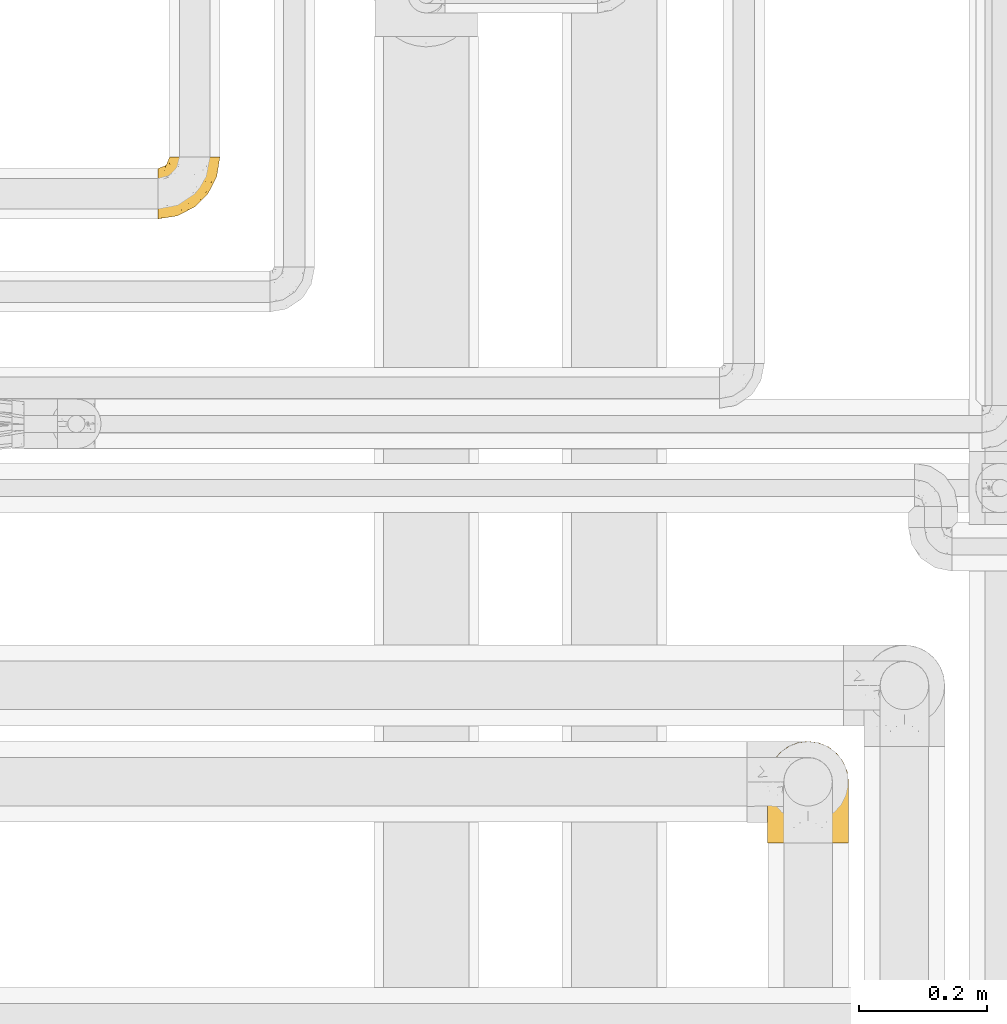
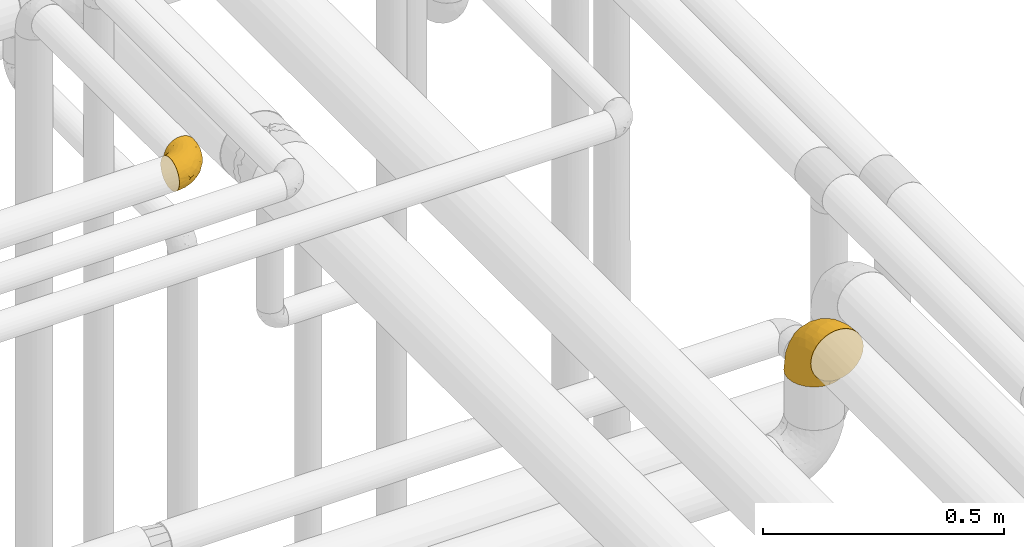
# One storey, part 494 of 827: 2 coverings.
"""IFC2X3 building model written with IfcOpenShell, lengths in millimetres."""

from ifc_helpers import new_model, entity, si_unit, converted_unit, derived_unit, direction, frame, origin, place, context, subcontext, project, spatial, faceted_brep, element, save


model = new_model("IFC2X3")

# Units and contexts
model_context = context("Model", 3, precision=0.01, world=origin(), true_north=direction((6.12303176911189e-17, 1.0)))
body_context = subcontext(model_context, "Body", "Model", "MODEL_VIEW")
ifc_project = project(units=[si_unit("LENGTHUNIT", "METRE", prefix="MILLI"), si_unit("AREAUNIT", "SQUARE_METRE"), si_unit("VOLUMEUNIT", "CUBIC_METRE"), converted_unit("PLANEANGLEUNIT", "DEGREE", entity("IfcRatioMeasure", 0.0174532925199433), si_unit("PLANEANGLEUNIT", "RADIAN"), dimensions=[0, 0, 0, 0, 0, 0, 0]), si_unit("MASSUNIT", "GRAM", prefix="KILO"), derived_unit("MASSDENSITYUNIT", [(si_unit("MASSUNIT", "GRAM", prefix="KILO"), 1), (si_unit("LENGTHUNIT", "METRE"), -3)]), derived_unit("MOMENTOFINERTIAUNIT", [(si_unit("LENGTHUNIT", "METRE"), 4)]), si_unit("TIMEUNIT", "SECOND"), si_unit("FREQUENCYUNIT", "HERTZ"), si_unit("THERMODYNAMICTEMPERATUREUNIT", "DEGREE_CELSIUS"), derived_unit("THERMALTRANSMITTANCEUNIT", [(si_unit("MASSUNIT", "GRAM", prefix="KILO"), 1), (si_unit("THERMODYNAMICTEMPERATUREUNIT", "KELVIN"), -1), (si_unit("TIMEUNIT", "SECOND"), -3)]), derived_unit("VOLUMETRICFLOWRATEUNIT", [(si_unit("LENGTHUNIT", "METRE"), 3), (si_unit("TIMEUNIT", "SECOND"), -1)]), derived_unit("MASSFLOWRATEUNIT", [(si_unit("MASSUNIT", "GRAM", prefix="KILO"), 1), (si_unit("TIMEUNIT", "SECOND"), -1)]), derived_unit("ROTATIONALFREQUENCYUNIT", [(si_unit("TIMEUNIT", "SECOND"), -1)]), si_unit("ELECTRICCURRENTUNIT", "AMPERE"), si_unit("ELECTRICVOLTAGEUNIT", "VOLT"), si_unit("POWERUNIT", "WATT"), si_unit("FORCEUNIT", "NEWTON", prefix="KILO"), si_unit("ILLUMINANCEUNIT", "LUX"), si_unit("LUMINOUSFLUXUNIT", "LUMEN"), si_unit("LUMINOUSINTENSITYUNIT", "CANDELA"), derived_unit("USERDEFINED", [(si_unit("MASSUNIT", "GRAM", prefix="KILO"), -1), (si_unit("LENGTHUNIT", "METRE"), -2), (si_unit("TIMEUNIT", "SECOND"), 3), (si_unit("LUMINOUSFLUXUNIT", "LUMEN"), 1)]), derived_unit("LINEARVELOCITYUNIT", [(si_unit("LENGTHUNIT", "METRE"), 1), (si_unit("TIMEUNIT", "SECOND"), -1)]), si_unit("PRESSUREUNIT", "PASCAL"), derived_unit("USERDEFINED", [(si_unit("LENGTHUNIT", "METRE"), -2), (si_unit("MASSUNIT", "GRAM", prefix="KILO"), 1), (si_unit("TIMEUNIT", "SECOND"), -2)]), derived_unit("LINEARFORCEUNIT", [(si_unit("MASSUNIT", "GRAM", prefix="KILO"), 1), (si_unit("LENGTHUNIT", "METRE"), 1), (si_unit("TIMEUNIT", "SECOND"), -2), (si_unit("LENGTHUNIT", "METRE"), -1)]), derived_unit("PLANARFORCEUNIT", [(si_unit("MASSUNIT", "GRAM", prefix="KILO"), 1), (si_unit("LENGTHUNIT", "METRE"), 1), (si_unit("TIMEUNIT", "SECOND"), -2), (si_unit("LENGTHUNIT", "METRE"), -2)])], contexts=[model_context])

# Site, building, storey
site_placement = place(None, origin())
site = spatial("IfcSite", under=ifc_project, at=site_placement, CompositionType="ELEMENT")
building_placement = place(site_placement, origin())
building = spatial("IfcBuilding", under=site, at=building_placement, CompositionType="ELEMENT")
storey_placement = place(building_placement, frame((0.0, 0.0, 28200.0)))
storey = spatial("IfcBuildingStorey", under=building, at=storey_placement, Name="08", CompositionType="ELEMENT", Elevation=28200.0)

# Coverings
covering_1_placement = place(storey_placement, frame((59739.54, 16797.19, 3159.25)))
element("IfcCovering", 1, at=covering_1_placement, inside=storey, Name=":ADSK_", ObjectType=":ADSK_", PredefinedType="INSULATION", context=body_context, shape_type="Brep", body=[
    faceted_brep([(58.6, 97.75, 79.9), (67.31, 97.75, 78.91), (75.59, 97.75, 76.02), (83.01, 97.75, 71.35), (89.21, 97.75, 65.15), (93.87, 97.75, 57.73), (96.76, 97.75, 49.45), (97.75, 97.75, 40.75), (96.76, 97.75, 32.03), (93.87, 97.75, 23.75), (89.2, 97.75, 16.33), (83.0, 97.75, 10.13), (75.58, 97.75, 5.47), (67.3, 97.75, 2.58), (58.6, 97.75, 1.6), (55.4, 97.75, 1.96), (49.88, 97.75, 2.58), (45.74, 97.75, 4.03), (41.6, 97.75, 5.48), (34.18, 97.75, 10.14), (27.98, 97.75, 16.34), (23.32, 97.75, 23.76), (20.43, 97.75, 32.04), (19.45, 97.75, 40.75), (20.43, 97.75, 49.46), (23.33, 97.75, 57.74), (27.99, 97.75, 65.16), (34.19, 97.75, 71.36), (41.61, 97.75, 76.02), (49.89, 97.75, 78.91), (55.4, 97.75, 79.54), (1.6, 68.43, 13.06), (1.6, 60.32, 6.84), (1.6, 50.88, 2.93), (1.6, 47.16, 2.44), (1.6, 43.95, 2.02), (1.6, 40.75, 1.6), (1.6, 30.61, 2.93), (1.6, 21.17, 6.84), (1.6, 13.06, 13.06), (1.6, 6.84, 21.17), (1.6, 2.93, 30.61), (1.6, 1.6, 40.75), (1.6, 2.93, 50.88), (1.6, 6.84, 60.32), (1.6, 13.06, 68.43), (1.6, 21.17, 74.65), (1.6, 30.61, 78.56), (1.6, 40.75, 79.9), (1.6, 47.16, 79.05), (1.6, 50.88, 78.56), (1.6, 60.32, 74.65), (1.6, 68.43, 68.43), (1.6, 74.65, 60.32), (1.6, 78.56, 50.88), (1.6, 79.9, 40.75), (1.6, 78.56, 30.61), (1.6, 74.65, 21.17), (68.75, 30.59, 40.75), (79.38, 41.23, 40.75), (67.95, 31.39, 53.99), (58.11, 19.96, 40.75), (31.31, 6.3, 40.75), (25.48, 5.21, 47.49), (20.85, 4.64, 40.75), (48.28, 15.42, 51.52), (38.29, 15.6, 61.86), (24.38, 6.88, 54.43), (18.7, 10.45, 63.37), (63.4, 80.79, 79.25), (43.9, 39.87, 77.04), (21.15, 25.91, 75.79), (41.26, 28.57, 72.61), (20.94, 35.0, 78.93), (24.69, 18.15, 70.12), (84.73, 74.57, 66.7), (79.29, 80.38, 72.7), (75.09, 59.65, 70.21), (55.53, 59.36, 78.8), (54.26, 75.93, 79.9), (51.17, 71.31, 79.9), (48.08, 66.69, 79.9), (44.99, 62.06, 79.9), (41.9, 57.44, 79.9), (59.1, 46.63, 74.44), (93.12, 74.83, 52.47), (38.11, 45.67, 79.33), (37.28, 54.35, 79.9), (32.65, 51.26, 79.9), (28.03, 48.17, 79.9), (23.41, 45.08, 79.9), (86.26, 54.03, 48.94), (84.36, 58.15, 58.78), (90.84, 80.8, 60.43), (94.7, 78.49, 40.75), (62.67, 31.82, 62.02), (76.37, 43.52, 57.53), (57.88, 94.17, 79.9), (57.17, 90.6, 79.9), (55.75, 83.46, 79.9), (74.1, 47.16, 64.12), (68.09, 64.11, 75.76), (72.38, 81.54, 76.65), (61.34, 38.43, 68.92), (48.69, 25.45, 66.73), (44.71, 13.13, 40.75), (93.04, 68.03, 40.75), (15.88, 43.59, 79.9), (12.31, 42.88, 79.9), (8.74, 42.17, 79.9), (86.21, 54.63, 40.75), (7.55, 73.05, 63.86), (12.14, 69.6, 69.15), (11.84, 51.66, 78.65), (9.55, 63.89, 72.98), (10.89, 57.82, 76.47), (17.57, 59.13, 76.82), (19.53, 52.25, 79.05), (25.5, 54.86, 79.09), (7.5, 79.38, 51.28), (12.73, 82.07, 51.03), (14.22, 85.12, 40.75), (8.19, 82.63, 40.75), (18.5, 89.2, 49.93), (20.38, 86.06, 58.53), (27.96, 81.78, 69.86), (22.53, 81.63, 65.19), (25.05, 76.19, 70.75), (51.05, 90.86, 79.25), (49.37, 85.89, 79.11), (6.49, 76.5, 57.89), (21.79, 92.32, 55.93), (37.29, 70.11, 78.06), (28.49, 69.83, 75.39), (33.82, 65.67, 78.16), (18.63, 76.0, 66.62), (21.37, 68.84, 73.14), (33.2, 91.37, 71.07), (42.33, 76.37, 78.32), (34.77, 83.17, 73.93), (42.81, 85.98, 77.25), (48.27, 79.95, 79.26), (17.49, 81.01, 60.3), (16.71, 91.15, 40.75), (26.81, 88.52, 65.72), (31.65, 75.86, 74.5), (12.9, 77.41, 60.62), (16.9, 64.86, 73.96), (23.37, 60.69, 77.3), (28.95, 62.7, 77.83), (6.49, 76.5, 23.6), (10.35, 73.85, 17.57), (57.88, 94.17, 1.6), (57.17, 90.6, 1.6), (55.75, 83.46, 1.6), (18.5, 89.2, 31.57), (20.37, 86.06, 22.97), (21.79, 92.32, 25.57), (26.8, 88.52, 15.78), (15.88, 43.59, 1.6), (8.74, 42.17, 1.6), (5.17, 41.46, 1.6), (12.14, 69.6, 12.34), (16.74, 64.84, 7.57), (10.0, 64.5, 8.85), (18.6, 52.81, 2.63), (17.57, 59.13, 4.67), (25.3, 54.5, 2.36), (23.41, 45.08, 1.6), (11.84, 51.66, 2.84), (48.27, 79.95, 2.24), (51.17, 71.31, 1.6), (42.31, 76.38, 3.18), (25.03, 76.18, 10.74), (18.73, 76.44, 15.18), (22.25, 81.43, 16.42), (7.5, 79.38, 30.21), (20.15, 70.71, 9.98), (12.73, 82.07, 30.46), (33.19, 91.37, 10.43), (27.5, 81.89, 12.05), (42.79, 85.98, 4.24), (34.75, 83.17, 7.56), (37.29, 70.11, 3.43), (49.36, 85.9, 2.38), (54.26, 75.93, 1.6), (28.95, 62.7, 3.66), (22.98, 61.23, 4.45), (31.63, 75.83, 6.98), (28.42, 69.82, 6.12), (10.01, 58.44, 5.38), (17.3, 81.13, 21.58), (48.08, 66.69, 1.6), (12.9, 77.41, 20.87), (33.78, 65.71, 3.35), (37.28, 54.35, 1.6), (41.9, 57.44, 1.6), (44.99, 62.06, 1.6), (28.03, 48.17, 1.6), (32.65, 51.26, 1.6), (38.11, 45.67, 2.16), (24.7, 18.15, 11.37), (21.15, 25.91, 5.7), (41.27, 28.58, 8.88), (61.33, 38.43, 12.57), (59.09, 46.64, 7.04), (75.08, 59.66, 11.27), (74.09, 47.16, 17.36), (55.53, 59.36, 2.69), (20.94, 35.0, 2.56), (25.48, 5.21, 34.0), (24.38, 6.88, 27.06), (43.89, 39.88, 4.45), (68.08, 64.12, 5.73), (18.7, 10.45, 18.12), (38.29, 15.6, 19.63), (67.95, 31.39, 27.49), (62.66, 31.82, 19.46), (63.4, 80.8, 2.24), (93.12, 74.83, 29.01), (84.73, 74.57, 14.78), (86.25, 54.02, 32.55), (79.28, 80.38, 8.78), (48.28, 15.42, 29.98), (76.37, 43.52, 23.95), (84.35, 58.15, 22.7), (90.83, 80.8, 21.05), (48.7, 25.47, 14.75), (72.37, 81.54, 4.84)], [[[0, 1, 2, 3, 4, 5, 6, 7, 8, 9, 10, 11, 12, 13, 14, 15, 16, 17, 18, 19, 20, 21, 22, 23, 24, 25, 26, 27, 28, 29, 30]], [[31, 32, 33, 34, 35, 36, 37, 38, 39, 40, 41, 42, 43, 44, 45, 46, 47, 48, 49, 50, 51, 52, 53, 54, 55, 56, 57]], [[58, 59, 60, 61]], [[62, 63, 64]], [[65, 66, 67]], [[67, 66, 68]], [[69, 1, 0]], [[70, 71, 72]], [[44, 43, 67]], [[47, 71, 73]], [[45, 74, 46]], [[68, 45, 44]], [[75, 76, 77]], [[76, 3, 2]], [[78, 79, 80, 81, 82, 83]], [[48, 47, 73]], [[70, 72, 84]], [[5, 85, 6]], [[86, 83, 87, 88, 89, 90]], [[91, 85, 92]], [[76, 75, 3]], [[71, 46, 74]], [[85, 5, 93]], [[45, 68, 74]], [[5, 4, 93]], [[85, 94, 6]], [[86, 78, 83]], [[60, 95, 65]], [[96, 95, 60]], [[75, 4, 3]], [[69, 0, 97, 98, 99, 79]], [[75, 77, 100]], [[43, 64, 63]], [[101, 102, 69]], [[101, 76, 102]], [[46, 71, 47]], [[95, 103, 104]], [[92, 85, 93]], [[63, 105, 65]], [[92, 75, 100]], [[91, 106, 85]], [[84, 78, 70]], [[67, 68, 44]], [[65, 67, 63]], [[65, 61, 60]], [[4, 75, 93]], [[92, 93, 75]], [[102, 76, 2]], [[77, 76, 101]], [[84, 77, 101]], [[77, 103, 100]], [[72, 71, 74]], [[70, 86, 73]], [[104, 74, 66]], [[84, 72, 103]], [[70, 73, 71]], [[73, 90, 107, 108, 109, 48]], [[79, 78, 69]], [[101, 69, 78]], [[91, 92, 96]], [[91, 59, 110, 106]], [[2, 1, 102]], [[69, 102, 1]], [[94, 85, 106]], [[94, 7, 6]], [[74, 68, 66]], [[43, 42, 64]], [[43, 63, 67]], [[73, 86, 90]], [[78, 86, 70]], [[95, 100, 103]], [[96, 92, 100]], [[104, 103, 72]], [[65, 95, 66]], [[74, 104, 72]], [[66, 95, 104]], [[95, 96, 100]], [[91, 96, 60]], [[77, 84, 103]], [[78, 84, 101]], [[60, 59, 91]], [[105, 63, 62]], [[105, 61, 65]], [[111, 52, 112]], [[107, 90, 113]], [[114, 115, 116]], [[50, 107, 113]], [[117, 118, 116]], [[54, 119, 55]], [[97, 0, 30, 29, 98]], [[113, 115, 51]], [[120, 121, 122]], [[123, 120, 124]], [[125, 126, 127]], [[128, 28, 129]], [[130, 54, 53]], [[25, 24, 131]], [[132, 133, 134]], [[135, 112, 136]], [[137, 27, 26]], [[121, 120, 123]], [[138, 139, 132]], [[129, 140, 141]], [[135, 126, 142]], [[27, 140, 28]], [[27, 137, 140]], [[49, 48, 109, 108, 107, 50]], [[23, 143, 121, 123]], [[25, 131, 144]], [[26, 25, 144]], [[128, 98, 29]], [[125, 127, 145]], [[146, 130, 111]], [[137, 144, 139]], [[139, 138, 140]], [[116, 147, 114]], [[123, 124, 131]], [[116, 118, 148]], [[138, 132, 81]], [[129, 79, 99]], [[54, 130, 119]], [[141, 79, 129]], [[122, 55, 119]], [[120, 146, 142]], [[117, 113, 90]], [[50, 113, 51]], [[127, 133, 145]], [[147, 136, 112]], [[136, 133, 127]], [[24, 23, 123]], [[118, 117, 89]], [[149, 87, 134]], [[144, 131, 124]], [[24, 123, 131]], [[128, 129, 99]], [[28, 140, 129]], [[144, 137, 26]], [[140, 137, 139]], [[134, 82, 132]], [[138, 80, 141]], [[89, 88, 87, 118]], [[115, 117, 116]], [[140, 138, 141]], [[148, 118, 149]], [[136, 148, 149]], [[147, 116, 148]], [[133, 136, 149]], [[127, 126, 135]], [[136, 147, 148]], [[114, 112, 52]], [[112, 114, 147]], [[51, 114, 52]], [[51, 115, 114]], [[117, 115, 113]], [[117, 90, 89]], [[134, 133, 149]], [[145, 133, 132]], [[132, 139, 145]], [[125, 139, 144]], [[139, 125, 145]], [[126, 144, 124]], [[144, 126, 125]], [[142, 126, 124]], [[120, 142, 124]], [[142, 146, 135]], [[112, 135, 146]], [[136, 127, 135]], [[118, 87, 149]], [[111, 130, 53]], [[119, 146, 120]], [[146, 119, 130]], [[122, 119, 120]], [[52, 111, 53]], [[146, 111, 112]], [[82, 134, 83]], [[82, 81, 132]], [[83, 134, 87]], [[98, 128, 99]], [[80, 138, 81]], [[80, 79, 141]], [[28, 128, 29]], [[150, 151, 57]], [[15, 14, 152, 153, 154, 16]], [[121, 143, 23, 155]], [[150, 57, 56]], [[156, 157, 158]], [[35, 34, 33, 159, 160, 161, 36]], [[162, 31, 57]], [[163, 164, 162]], [[165, 166, 167]], [[155, 23, 22]], [[168, 159, 169]], [[170, 171, 172]], [[173, 174, 175]], [[55, 122, 176]], [[177, 174, 173]], [[22, 157, 155]], [[178, 121, 155]], [[169, 33, 32]], [[20, 19, 179]], [[21, 20, 158]], [[158, 180, 175]], [[181, 182, 179]], [[172, 183, 182]], [[122, 121, 178]], [[181, 19, 18]], [[184, 185, 170]], [[17, 154, 184]], [[186, 187, 177]], [[187, 186, 167]], [[179, 158, 20]], [[21, 157, 22]], [[175, 180, 173]], [[188, 189, 173]], [[164, 166, 190]], [[185, 184, 154]], [[181, 172, 182]], [[156, 191, 178]], [[192, 183, 172]], [[178, 176, 122]], [[193, 150, 176]], [[33, 169, 159]], [[190, 169, 32]], [[189, 194, 186]], [[180, 188, 173]], [[167, 166, 187]], [[166, 164, 163]], [[195, 194, 196]], [[158, 157, 21]], [[155, 157, 156]], [[178, 155, 156]], [[181, 18, 184]], [[17, 16, 154]], [[181, 179, 19]], [[158, 179, 182]], [[170, 181, 184]], [[196, 194, 197]], [[31, 190, 32]], [[165, 190, 166]], [[190, 31, 164]], [[31, 162, 164]], [[177, 163, 162]], [[187, 166, 163]], [[151, 174, 177]], [[177, 173, 189]], [[177, 187, 163]], [[195, 167, 186]], [[165, 198, 168]], [[165, 168, 169]], [[167, 198, 165]], [[190, 165, 169]], [[167, 195, 199, 198]], [[151, 177, 162]], [[175, 191, 156]], [[191, 174, 193]], [[158, 175, 156]], [[174, 191, 175]], [[178, 191, 193]], [[158, 182, 180]], [[188, 182, 183]], [[182, 188, 180]], [[183, 194, 189]], [[183, 189, 188]], [[177, 189, 186]], [[194, 183, 197]], [[176, 150, 56]], [[151, 150, 193]], [[176, 56, 55]], [[193, 176, 178]], [[174, 151, 193]], [[57, 151, 162]], [[183, 192, 197]], [[194, 195, 186]], [[171, 192, 172]], [[172, 181, 170]], [[170, 185, 171]], [[184, 18, 17]], [[200, 168, 198, 199, 195, 196]], [[201, 202, 203]], [[204, 203, 205]], [[204, 206, 207]], [[208, 196, 197, 192, 171, 185]], [[209, 36, 161, 160, 159, 168]], [[202, 38, 37]], [[201, 38, 202]], [[210, 41, 211]], [[200, 208, 212]], [[205, 208, 213]], [[214, 211, 40]], [[40, 211, 41]], [[214, 201, 215]], [[58, 61, 216, 59]], [[201, 39, 38]], [[207, 217, 204]], [[213, 208, 218]], [[218, 185, 154, 153, 152, 14]], [[14, 13, 218]], [[9, 8, 219]], [[10, 220, 11]], [[221, 106, 110, 59]], [[219, 8, 94]], [[220, 222, 11]], [[223, 211, 215]], [[221, 216, 224]], [[225, 219, 221]], [[10, 9, 226]], [[213, 222, 206]], [[226, 9, 219]], [[106, 219, 94]], [[212, 202, 209]], [[201, 203, 227]], [[226, 225, 220]], [[207, 206, 220]], [[214, 40, 39]], [[11, 222, 12]], [[12, 222, 228]], [[41, 210, 64]], [[223, 105, 210]], [[223, 215, 217]], [[105, 62, 210]], [[206, 222, 220]], [[228, 222, 213]], [[207, 220, 225]], [[205, 206, 204]], [[225, 226, 219]], [[220, 10, 226]], [[209, 202, 37]], [[203, 202, 212]], [[205, 203, 212]], [[204, 217, 227]], [[36, 209, 37]], [[209, 168, 200]], [[218, 13, 228]], [[208, 185, 218]], [[106, 221, 219]], [[221, 59, 216]], [[218, 228, 213]], [[13, 12, 228]], [[8, 7, 94]], [[201, 214, 39]], [[211, 214, 215]], [[64, 210, 62]], [[64, 42, 41]], [[223, 210, 211]], [[208, 200, 196]], [[209, 200, 212]], [[225, 224, 207]], [[207, 224, 217]], [[223, 217, 216]], [[204, 227, 203]], [[217, 215, 227]], [[201, 227, 215]], [[221, 224, 225]], [[217, 224, 216]], [[208, 205, 212]], [[206, 205, 213]], [[216, 61, 223]], [[223, 61, 105]]]),
])
covering_2_placement = place(storey_placement, frame((60688.46, 15825.78, 2903.4)))
element("IfcCovering", 2, at=covering_2_placement, inside=storey, Name=":ADSK_", ObjectType=":ADSK_", PredefinedType="INSULATION", context=body_context, shape_type="Brep", body=[
    faceted_brep([(126.11, 1.6, 110.62), (121.45, 1.6, 123.95), (113.94, 1.6, 135.9), (103.96, 1.6, 145.89), (92.0, 1.6, 153.4), (78.68, 1.6, 158.06), (64.65, 1.6, 159.65), (50.62, 1.6, 158.06), (37.29, 1.6, 153.4), (25.34, 1.6, 145.89), (15.35, 1.6, 135.91), (7.84, 1.6, 123.95), (3.18, 1.6, 110.63), (1.6, 1.6, 96.6), (3.18, 1.6, 82.57), (7.84, 1.6, 69.24), (15.35, 1.6, 57.29), (25.33, 1.6, 47.3), (37.29, 1.6, 39.79), (50.61, 1.6, 35.13), (64.65, 1.6, 33.55), (78.67, 1.6, 35.13), (92.0, 1.6, 39.79), (103.95, 1.6, 47.3), (113.94, 1.6, 57.28), (121.45, 1.6, 69.24), (126.11, 1.6, 82.56), (127.7, 1.6, 96.6), (64.65, 33.55, 1.6), (48.33, 35.69, 1.6), (33.12, 41.99, 1.6), (20.06, 52.01, 1.6), (10.04, 65.07, 1.6), (3.74, 80.28, 1.6), (3.01, 85.89, 1.6), (1.6, 96.6, 1.6), (3.74, 112.91, 1.6), (10.04, 128.12, 1.6), (20.06, 141.18, 1.6), (33.12, 151.2, 1.6), (48.33, 157.5, 1.6), (64.65, 159.65, 1.6), (80.96, 157.5, 1.6), (96.17, 151.2, 1.6), (109.23, 141.18, 1.6), (119.25, 128.12, 1.6), (125.55, 112.91, 1.6), (127.7, 96.6, 1.6), (126.29, 85.89, 1.6), (125.55, 80.28, 1.6), (119.25, 65.07, 1.6), (109.23, 52.01, 1.6), (96.17, 41.99, 1.6), (80.96, 35.69, 1.6), (101.1, 145.23, 30.13), (86.72, 150.95, 39.4), (98.7, 136.48, 62.65), (75.93, 156.3, 28.52), (64.65, 154.26, 42.5), (113.39, 73.92, 115.57), (111.06, 98.94, 98.94), (96.87, 102.72, 111.29), (84.07, 124.89, 95.5), (64.65, 138.47, 80.62), (64.65, 113.35, 113.35), (119.56, 120.33, 43.71), (112.75, 118.42, 70.76), (122.85, 103.99, 62.71), (125.08, 110.05, 33.16), (126.64, 94.6, 53.41), (105.78, 62.68, 130.65), (93.81, 66.8, 137.68), (96.07, 37.71, 146.84), (87.11, 141.12, 66.58), (75.77, 148.29, 57.7), (111.99, 132.76, 39.88), (64.65, 42.5, 154.26), (83.58, 39.36, 152.07), (80.96, 96.16, 125.54), (78.34, 69.16, 142.81), (122.85, 62.71, 103.99), (125.88, 79.4, 79.4), (120.97, 88.81, 88.81), (126.67, 26.93, 104.86), (122.64, 32.13, 117.38), (127.7, 78.45, 57.43), (127.7, 85.2, 44.19), (127.7, 91.95, 30.95), (107.12, 31.66, 139.96), (115.07, 45.38, 127.03), (102.81, 118.88, 87.17), (127.7, 57.43, 78.45), (127.7, 62.69, 73.2), (127.7, 67.94, 67.94), (127.7, 13.99, 94.63), (127.7, 22.47, 93.29), (127.7, 30.95, 91.95), (126.64, 53.41, 94.6), (127.7, 44.19, 85.2), (64.65, 80.62, 138.47), (127.7, 94.63, 13.99), (113.05, 39.95, 40.46), (101.81, 33.15, 32.36), (108.46, 43.2, 28.71), (126.21, 81.77, 15.53), (122.65, 66.3, 29.06), (126.55, 75.23, 40.03), (125.45, 66.55, 45.36), (126.01, 78.18, 26.46), (123.3, 56.85, 47.56), (118.99, 54.23, 36.28), (113.51, 12.94, 55.57), (104.6, 17.42, 45.02), (118.04, 27.05, 57.55), (101.6, 44.37, 11.56), (109.98, 49.66, 19.2), (92.1, 38.88, 10.07), (96.28, 37.08, 21.04), (121.05, 66.96, 15.52), (79.4, 32.99, 13.84), (79.19, 14.52, 32.67), (80.39, 26.32, 24.86), (93.14, 22.37, 34.31), (126.75, 27.96, 81.47), (125.71, 39.47, 71.26), (126.17, 15.41, 81.64), (64.65, 17.57, 29.26), (123.28, 21.32, 70.65), (64.65, 7.61, 31.93), (91.58, 28.92, 27.99), (107.1, 28.65, 41.71), (116.28, 34.82, 50.14), (116.32, 58.27, 17.57), (90.34, 11.73, 37.62), (122.74, 40.36, 60.48), (64.65, 29.26, 17.57), (126.77, 65.12, 56.96), (119.84, 45.4, 48.98), (124.71, 53.05, 57.29), (126.47, 50.39, 68.25), (37.19, 38.88, 10.07), (27.66, 42.9, 16.58), (49.9, 32.99, 13.84), (1.6, 94.63, 13.99), (50.1, 14.52, 32.67), (48.89, 26.32, 24.86), (2.88, 50.51, 67.81), (6.55, 39.41, 61.09), (3.58, 39.47, 71.26), (1.6, 78.45, 57.43), (1.6, 85.2, 44.19), (2.74, 75.23, 40.03), (11.25, 27.05, 57.55), (11.93, 36.34, 51.01), (21.09, 28.89, 42.79), (3.28, 78.18, 26.46), (6.64, 66.3, 29.06), (12.97, 58.27, 17.57), (19.31, 49.66, 19.2), (16.23, 39.95, 40.46), (21.44, 42.42, 28.84), (26.96, 32.56, 33.48), (8.24, 66.96, 15.52), (3.08, 81.77, 15.53), (10.3, 54.23, 36.28), (38.95, 11.73, 37.62), (33.01, 37.08, 21.04), (1.6, 13.99, 94.63), (1.6, 22.47, 93.29), (36.15, 22.37, 34.31), (24.69, 17.42, 45.03), (6.01, 21.32, 70.65), (2.54, 27.96, 81.47), (15.78, 12.94, 55.58), (1.6, 30.95, 91.95), (3.12, 15.41, 81.64), (37.33, 29.3, 27.86), (1.6, 57.43, 78.45), (1.6, 44.19, 85.2), (2.52, 65.12, 56.96), (3.84, 66.55, 45.36), (5.99, 56.85, 47.57), (9.35, 46.41, 48.27), (1.6, 67.94, 67.94), (4.58, 53.04, 57.3), (1.6, 91.95, 30.95), (30.59, 136.48, 62.65), (28.19, 145.23, 30.13), (17.3, 132.76, 39.88), (9.73, 120.33, 43.71), (42.57, 150.95, 39.4), (53.51, 149.01, 55.79), (53.42, 156.33, 28.41), (2.65, 94.6, 53.41), (2.62, 26.93, 104.86), (6.66, 32.14, 117.39), (6.44, 62.71, 103.99), (48.33, 96.16, 125.54), (32.42, 102.72, 111.29), (35.49, 66.79, 137.69), (2.65, 53.41, 94.6), (3.41, 79.4, 79.4), (4.21, 110.05, 33.16), (43.07, 140.44, 68.78), (23.52, 62.68, 130.66), (22.18, 31.66, 139.97), (33.1, 29.31, 148.6), (15.9, 73.92, 115.58), (14.23, 45.39, 127.03), (16.54, 118.42, 70.76), (45.22, 124.89, 95.5), (6.44, 103.99, 62.71), (8.33, 88.81, 88.81), (18.23, 98.94, 98.94), (32.99, 122.85, 89.09), (53.35, 138.38, 78.72), (48.76, 69.18, 142.21), (45.72, 39.36, 152.07)], [[[0, 1, 2, 3, 4, 5, 6, 7, 8, 9, 10, 11, 12, 13, 14, 15, 16, 17, 18, 19, 20, 21, 22, 23, 24, 25, 26, 27]], [[28, 29, 30, 31, 32, 33, 34, 35, 36, 37, 38, 39, 40, 41, 42, 43, 44, 45, 46, 47, 48, 49, 50, 51, 52, 53]], [[54, 55, 56]], [[57, 41, 58]], [[59, 60, 61]], [[62, 63, 64]], [[65, 66, 67]], [[68, 67, 69]], [[70, 71, 72]], [[55, 73, 56]], [[43, 42, 55]], [[55, 74, 73]], [[44, 75, 45]], [[44, 43, 54]], [[76, 5, 77]], [[71, 78, 79]], [[45, 75, 65]], [[46, 68, 47]], [[80, 81, 82]], [[0, 83, 84]], [[69, 85, 86, 87]], [[69, 81, 85]], [[84, 1, 0]], [[2, 88, 3]], [[4, 3, 72]], [[44, 54, 75]], [[5, 4, 77]], [[89, 2, 1]], [[72, 3, 88]], [[5, 76, 6]], [[70, 88, 89]], [[68, 65, 67]], [[88, 2, 89]], [[56, 90, 66]], [[64, 78, 62]], [[81, 91, 92, 93, 85]], [[83, 27, 94, 95, 96]], [[62, 61, 90]], [[97, 96, 98, 91]], [[80, 97, 81]], [[42, 57, 55]], [[62, 78, 61]], [[84, 89, 1]], [[78, 64, 99]], [[57, 74, 55]], [[76, 77, 79]], [[77, 72, 71]], [[82, 81, 67]], [[97, 83, 96]], [[80, 89, 84]], [[79, 78, 99]], [[71, 70, 61]], [[81, 97, 91]], [[83, 80, 84]], [[68, 87, 100, 47]], [[81, 69, 67]], [[68, 69, 87]], [[65, 46, 45]], [[65, 68, 46]], [[66, 65, 75]], [[56, 66, 75]], [[66, 60, 82]], [[71, 61, 78]], [[60, 66, 90]], [[83, 97, 80]], [[27, 83, 0]], [[59, 70, 89]], [[70, 59, 61]], [[89, 80, 59]], [[82, 59, 80]], [[55, 54, 43]], [[75, 54, 56]], [[66, 82, 67]], [[59, 82, 60]], [[41, 57, 42]], [[74, 57, 58]], [[58, 63, 74]], [[62, 74, 63]], [[74, 62, 73]], [[62, 56, 73]], [[4, 72, 77]], [[70, 72, 88]], [[76, 79, 99]], [[71, 79, 77]], [[62, 90, 56]], [[60, 90, 61]], [[101, 102, 103]], [[100, 87, 104]], [[105, 106, 107]], [[108, 104, 87]], [[107, 109, 110]], [[108, 87, 86]], [[111, 112, 113]], [[114, 51, 115]], [[116, 114, 117]], [[51, 50, 118]], [[119, 28, 53]], [[120, 121, 122]], [[98, 123, 124]], [[125, 96, 95]], [[116, 53, 52]], [[126, 121, 120]], [[104, 108, 118]], [[98, 124, 91]], [[25, 24, 127]], [[120, 128, 126]], [[122, 129, 102]], [[95, 94, 27, 26]], [[122, 102, 130]], [[125, 127, 123]], [[24, 111, 127]], [[21, 20, 128]], [[112, 130, 131]], [[48, 47, 100, 49]], [[132, 110, 115]], [[23, 111, 24]], [[129, 119, 117]], [[120, 133, 21]], [[112, 23, 22]], [[134, 113, 131]], [[121, 126, 135]], [[133, 112, 22]], [[128, 120, 21]], [[132, 51, 118]], [[120, 122, 133]], [[119, 121, 135]], [[129, 117, 102]], [[125, 26, 25]], [[26, 125, 95]], [[127, 125, 25]], [[28, 119, 135]], [[119, 53, 116]], [[127, 113, 124]], [[96, 125, 123]], [[112, 131, 113]], [[101, 103, 110]], [[85, 93, 136]], [[124, 123, 127]], [[98, 96, 123]], [[112, 111, 23]], [[127, 111, 113]], [[112, 133, 122]], [[21, 133, 22]], [[107, 110, 105]], [[110, 109, 137]], [[86, 106, 108]], [[138, 109, 136]], [[105, 118, 108]], [[107, 106, 85]], [[104, 50, 49]], [[124, 134, 139]], [[138, 93, 92]], [[92, 91, 139]], [[100, 104, 49]], [[118, 105, 132]], [[104, 118, 50]], [[110, 132, 105]], [[51, 132, 115]], [[108, 106, 105]], [[85, 106, 86]], [[114, 116, 52]], [[119, 116, 117]], [[51, 114, 52]], [[114, 115, 103]], [[117, 114, 103]], [[130, 102, 101]], [[117, 103, 102]], [[110, 103, 115]], [[130, 101, 131]], [[122, 130, 112]], [[101, 137, 131]], [[113, 134, 124]], [[137, 134, 131]], [[124, 139, 91]], [[134, 138, 139]], [[92, 139, 138]], [[110, 137, 101]], [[134, 137, 138]], [[136, 109, 107]], [[137, 109, 138]], [[85, 136, 107]], [[138, 136, 93]], [[122, 121, 129]], [[129, 121, 119]], [[30, 140, 141]], [[30, 29, 140]], [[28, 135, 142]], [[143, 35, 34, 33]], [[19, 144, 128]], [[126, 145, 135]], [[146, 147, 148]], [[149, 150, 151]], [[152, 153, 154]], [[155, 156, 151]], [[157, 31, 158]], [[159, 160, 161]], [[32, 162, 163]], [[158, 31, 30]], [[157, 164, 156]], [[126, 144, 145]], [[126, 128, 144]], [[18, 165, 19]], [[141, 166, 160]], [[14, 13, 167, 168]], [[163, 143, 33]], [[169, 165, 170]], [[18, 17, 170]], [[153, 159, 154]], [[142, 135, 145]], [[148, 171, 172]], [[159, 161, 154]], [[171, 152, 173]], [[173, 17, 16]], [[16, 15, 171]], [[158, 160, 164]], [[174, 175, 168]], [[173, 170, 17]], [[19, 128, 20]], [[174, 172, 175]], [[165, 169, 144]], [[162, 157, 156]], [[175, 172, 171]], [[144, 169, 145]], [[176, 169, 161]], [[166, 140, 142]], [[175, 171, 15]], [[168, 175, 14]], [[14, 175, 15]], [[142, 145, 176]], [[28, 142, 29]], [[148, 177, 146]], [[148, 178, 177]], [[152, 171, 148]], [[179, 180, 181]], [[164, 180, 156]], [[174, 178, 172]], [[148, 172, 178]], [[171, 173, 16]], [[170, 173, 152]], [[19, 165, 144]], [[170, 165, 18]], [[153, 182, 159]], [[146, 183, 184]], [[181, 180, 164]], [[180, 151, 156]], [[163, 155, 185]], [[155, 150, 185]], [[162, 156, 155]], [[143, 163, 185]], [[180, 179, 149]], [[32, 163, 33]], [[163, 162, 155]], [[31, 162, 32]], [[31, 157, 162]], [[164, 157, 158]], [[149, 151, 180]], [[155, 151, 150]], [[142, 140, 29]], [[141, 140, 166]], [[176, 145, 169]], [[30, 141, 158]], [[164, 160, 159]], [[158, 141, 160]], [[166, 161, 160]], [[154, 169, 170]], [[169, 154, 161]], [[152, 154, 170]], [[147, 152, 148]], [[153, 147, 182]], [[181, 182, 184]], [[164, 159, 182]], [[161, 166, 176]], [[142, 176, 166]], [[183, 146, 177]], [[184, 182, 147]], [[184, 147, 146]], [[152, 147, 153]], [[182, 181, 164]], [[179, 184, 183]], [[184, 179, 181]], [[149, 179, 183]], [[186, 187, 188]], [[37, 36, 189]], [[190, 191, 192]], [[193, 185, 150, 149]], [[194, 195, 196]], [[197, 198, 199]], [[200, 201, 177]], [[193, 202, 185]], [[203, 190, 186]], [[202, 189, 36]], [[41, 40, 192]], [[204, 205, 199]], [[9, 8, 206]], [[187, 190, 39]], [[40, 39, 190]], [[38, 37, 188]], [[207, 208, 204]], [[202, 35, 143, 185]], [[39, 38, 187]], [[195, 11, 208]], [[201, 149, 183, 177]], [[188, 189, 209]], [[197, 64, 210]], [[186, 188, 209]], [[13, 12, 194]], [[211, 201, 212]], [[12, 11, 195]], [[193, 201, 211]], [[212, 201, 196]], [[10, 208, 11]], [[213, 214, 209]], [[64, 63, 215]], [[216, 197, 199]], [[8, 217, 206]], [[7, 217, 8]], [[203, 191, 190]], [[7, 6, 76]], [[208, 205, 204]], [[205, 10, 9]], [[199, 205, 206]], [[7, 76, 217]], [[205, 208, 10]], [[216, 76, 99]], [[200, 177, 178, 174]], [[64, 197, 99]], [[63, 58, 191]], [[208, 196, 195]], [[196, 200, 194]], [[198, 197, 210]], [[216, 199, 217]], [[201, 193, 149]], [[202, 193, 211]], [[202, 211, 189]], [[35, 202, 36]], [[211, 212, 209]], [[37, 189, 188]], [[211, 209, 189]], [[213, 198, 214]], [[200, 174, 194]], [[201, 200, 196]], [[214, 198, 210]], [[213, 207, 198]], [[194, 174, 168, 167, 13]], [[195, 194, 12]], [[198, 204, 199]], [[204, 198, 207]], [[212, 207, 213]], [[196, 208, 207]], [[188, 187, 38]], [[190, 187, 186]], [[207, 212, 196]], [[209, 212, 213]], [[214, 203, 186]], [[191, 215, 63]], [[191, 203, 215]], [[192, 191, 58]], [[41, 192, 58]], [[190, 192, 40]], [[203, 210, 215]], [[64, 215, 210]], [[199, 206, 217]], [[9, 206, 205]], [[76, 216, 217]], [[99, 197, 216]], [[203, 214, 210]], [[209, 214, 186]]]),
])

save(model, "model.ifc")
